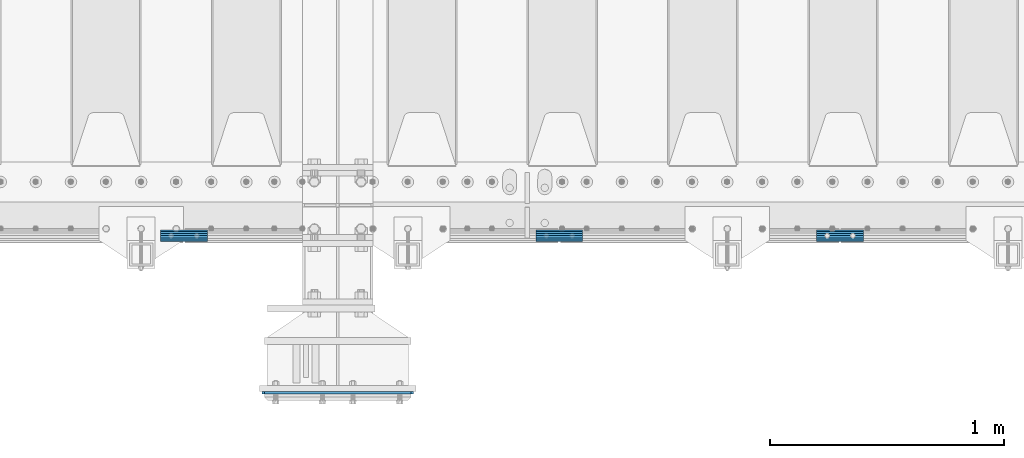
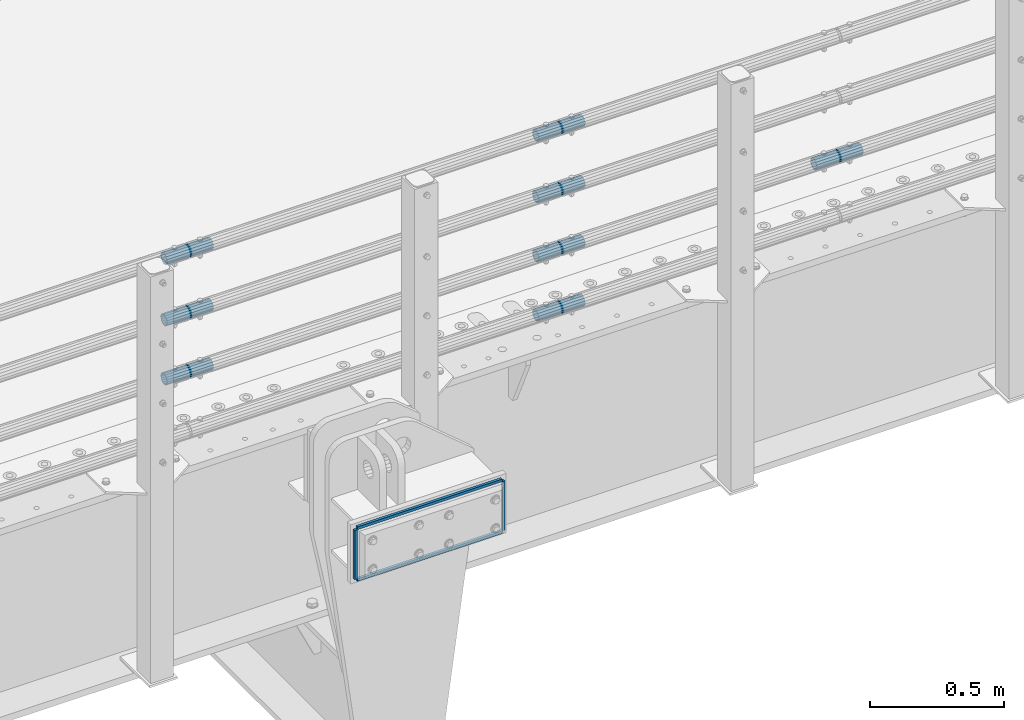
# One storey, part 116 of 193: 12 beams.
"""IFC2X3 building model written with IfcOpenShell, lengths in millimetres."""

from ifc_helpers import new_model, si_unit, frame, origin_with_axes, place, context, subcontext, project, spatial, faceted_brep, material, type_object, element, save


model = new_model("IFC2X3")

# Units and contexts
model_context = context("Model", 3, precision=1e-05, world=origin_with_axes())
body_context = subcontext(model_context, "Body", "Model", "MODEL_VIEW")
ifc_project = project(units=[si_unit("LENGTHUNIT", "METRE", prefix="MILLI"), si_unit("AREAUNIT", "SQUARE_METRE"), si_unit("VOLUMEUNIT", "CUBIC_METRE"), si_unit("MASSUNIT", "GRAM", prefix="KILO"), si_unit("TIMEUNIT", "SECOND"), si_unit("PLANEANGLEUNIT", "RADIAN"), si_unit("SOLIDANGLEUNIT", "STERADIAN"), si_unit("THERMODYNAMICTEMPERATUREUNIT", "DEGREE_CELSIUS"), si_unit("LUMINOUSINTENSITYUNIT", "LUMEN")], contexts=[model_context])

# Site, building, storey
site_placement = place(None, origin_with_axes())
site = spatial("IfcSite", under=ifc_project, at=site_placement, CompositionType="ELEMENT")
building_placement = place(site_placement, origin_with_axes())
building = spatial("IfcBuilding", under=site, at=building_placement, Name="Standard", CompositionType="ELEMENT")
storey_placement = place(building_placement, origin_with_axes())
storey = spatial("IfcBuildingStorey", under=building, at=storey_placement, Name="Undefined", CompositionType="ELEMENT", Elevation=0.0)

# Beams
ifc_material_1 = material(Name="STEEL/S355N")
beam_type_1 = type_object("IfcBeamType", PredefinedType="NOTDEFINED")
for number, where, z_axis, x_axis in (
    (1, (-32378.499999934, 23198.9999999954, -12.500018206186), (-1.0, 0.0, 0.0), (0.0, 0.0, -1.0)),
    (2, (-31741.4999999322, 23198.9999999952, -12.500018206186), (-1.0, 0.0, 0.0), (0.0, 0.0, -1.0)),
):
    element("IfcBeam", number, at=place(storey_placement, frame(where, z_axis=z_axis, x_axis=x_axis)), inside=storey, type_object=beam_type_1, material=ifc_material_1, context=body_context, shape_type="Brep", body=[
        faceted_brep([(0.0, 6.0, -6.0), (0.0, 6.0, 6.0), (225.0, 6.0, 6.0), (225.0, 6.0, -6.0), (0.0, -6.0, 6.0), (225.0, -6.0, 6.0), (0.0, -6.0, -6.0), (225.0, -6.0, -6.0)], [[[0, 1, 2, 3]], [[1, 4, 5, 2]], [[4, 6, 7, 5]], [[6, 0, 3, 7]], [[5, 7, 3, 2]], [[6, 4, 1, 0]]]),
    ])
for number, where, z_axis, x_axis in (
    (3, (-32372.4999999339, 23198.9999999954, -6.50001820618604), (0.0, 0.0, -1.0), (1.0, 0.0, 0.0)),
    (4, (-32372.4999999339, 23198.9999999954, -243.500018206186), (0.0, 0.0, -1.0), (1.0, 0.0, 0.0)),
):
    element("IfcBeam", number, at=place(storey_placement, frame(where, z_axis=z_axis, x_axis=x_axis)), inside=storey, type_object=beam_type_1, material=ifc_material_1, context=body_context, shape_type="Brep", body=[
        faceted_brep([(0.0, 6.0, -6.0), (0.0, 6.0, 6.0), (625.000000001688, 6.0, 6.0), (625.000000001688, 6.0, -6.0), (0.0, -6.0, 6.0), (625.000000001688, -6.0, 6.0), (0.0, -6.0, -6.0), (625.000000001688, -6.0, -6.0)], [[[0, 1, 2, 3]], [[1, 4, 5, 2]], [[4, 6, 7, 5]], [[6, 0, 3, 7]], [[5, 7, 3, 2]], [[6, 4, 1, 0]]]),
    ])
ifc_material_2 = material()
beam_type_2 = type_object("IfcBeamType", PredefinedType="NOTDEFINED")
beam_1_placement = place(storey_placement, frame((-31213.0024970001, 23870.1500000004, 149.849999999747), z_axis=(0.0, 0.0, 1.0), x_axis=(1.0, 0.0, 0.0)))
element("IfcBeam", 5, at=beam_1_placement, inside=storey, type_object=beam_type_2, material=ifc_material_2, context=body_context, shape_type="Brep", body=[
    faceted_brep([(0.0, -21.9000000000015, 0.0), (0.0, -20.232961761998, 8.38076716879547), (200.0, -20.232961761998, 8.38076716879547), (200.0, -21.9000000000015, 0.0), (0.0, -15.4856385079838, 15.4856385079854), (200.0, -15.4856385079838, 15.4856385079854), (0.0, -8.38076716879368, 20.2329617619972), (200.0, -8.38076716879368, 20.2329617619972), (0.0, 0.0, 21.9), (200.0, 0.0, 21.9), (0.0, 8.38076716879368, 20.2329617619972), (200.0, 8.38076716879368, 20.2329617619972), (0.0, 15.4856385079838, 15.4856385079854), (200.0, 15.4856385079838, 15.4856385079854), (0.0, 20.232961761998, 8.38076716879547), (200.0, 20.232961761998, 8.38076716879547), (0.0, 21.9000000000015, 0.0), (200.0, 21.9000000000015, 0.0), (0.0, 20.232961761998, -8.38076716879547), (200.0, 20.232961761998, -8.38076716879547), (0.0, 15.4856385079838, -15.4856385079854), (200.0, 15.4856385079838, -15.4856385079854), (0.0, 8.38076716879368, -20.2329617619972), (200.0, 8.38076716879368, -20.2329617619972), (0.0, 0.0, -21.9), (200.0, 0.0, -21.9), (0.0, -8.38076716879368, -20.2329617619972), (200.0, -8.38076716879368, -20.2329617619972), (0.0, -15.4856385079838, -15.4856385079854), (200.0, -15.4856385079838, -15.4856385079854), (0.0, -20.232961761998, -8.38076716879547), (200.0, -20.232961761998, -8.38076716879547), (0.0, -25.5, 0.0), (0.0, -23.5589280790373, -9.7584275253098), (200.0, -23.5589280790373, -9.7584275253098), (200.0, -25.5, 0.0), (0.0, -18.0312229202573, -18.031222920257), (200.0, -18.0312229202573, -18.031222920257), (0.0, -9.75842752531025, -23.5589280790378), (200.0, -9.75842752531025, -23.5589280790378), (0.0, 0.0, -25.5), (200.0, 0.0, -25.5), (0.0, 9.75842752531025, -23.5589280790378), (200.0, 9.75842752531025, -23.5589280790378), (0.0, 18.0312229202573, -18.031222920257), (200.0, 18.0312229202573, -18.031222920257), (0.0, 23.5589280790373, -9.7584275253098), (200.0, 23.5589280790373, -9.7584275253098), (0.0, 25.5, 0.0), (200.0, 25.5, 0.0), (0.0, 23.5589280790373, 9.7584275253098), (200.0, 23.5589280790373, 9.7584275253098), (0.0, 18.0312229202573, 18.031222920257), (200.0, 18.0312229202573, 18.031222920257), (0.0, 9.75842752531025, 23.5589280790378), (200.0, 9.75842752531025, 23.5589280790378), (0.0, 0.0, 25.5), (200.0, 0.0, 25.5), (0.0, -9.75842752531025, 23.5589280790378), (200.0, -9.75842752531025, 23.5589280790378), (0.0, -18.0312229202573, 18.031222920257), (200.0, -18.0312229202573, 18.031222920257), (0.0, -23.5589280790373, 9.7584275253098), (200.0, -23.5589280790373, 9.7584275253098)], [[[0, 1, 2, 3]], [[1, 4, 5, 2]], [[4, 6, 7, 5]], [[6, 8, 9, 7]], [[8, 10, 11, 9]], [[10, 12, 13, 11]], [[12, 14, 15, 13]], [[14, 16, 17, 15]], [[16, 18, 19, 17]], [[18, 20, 21, 19]], [[20, 22, 23, 21]], [[22, 24, 25, 23]], [[24, 26, 27, 25]], [[26, 28, 29, 27]], [[28, 30, 31, 29]], [[30, 0, 3, 31]], [[32, 33, 34, 35]], [[33, 36, 37, 34]], [[36, 38, 39, 37]], [[38, 40, 41, 39]], [[40, 42, 43, 41]], [[42, 44, 45, 43]], [[44, 46, 47, 45]], [[46, 48, 49, 47]], [[48, 50, 51, 49]], [[50, 52, 53, 51]], [[52, 54, 55, 53]], [[54, 56, 57, 55]], [[56, 58, 59, 57]], [[58, 60, 61, 59]], [[60, 62, 63, 61]], [[62, 32, 35, 63]], [[37, 39, 41, 43, 45, 47, 49, 51, 53, 55, 57, 59, 61, 63, 35, 34], [5, 7, 9, 11, 13, 15, 17, 19, 21, 23, 25, 27, 29, 31, 3, 2]], [[62, 60, 58, 56, 54, 52, 50, 48, 46, 44, 42, 40, 38, 36, 33, 32], [30, 28, 26, 24, 22, 20, 18, 16, 14, 12, 10, 8, 6, 4, 1, 0]]]),
])
beam_2_placement = place(storey_placement, frame((-32817.0024970001, 23870.1500000004, 420.149999999747), z_axis=(0.0, 0.0, 1.0), x_axis=(1.0, 0.0, 0.0)))
element("IfcBeam", 6, at=beam_2_placement, inside=storey, type_object=beam_type_2, material=ifc_material_2, context=body_context, shape_type="Brep", body=[
    faceted_brep([(0.0, -21.9000000000015, 0.0), (0.0, -20.232961761998, 8.38076716879547), (200.0, -20.232961761998, 8.38076716879547), (200.0, -21.9000000000015, 0.0), (0.0, -15.4856385079838, 15.4856385079854), (200.0, -15.4856385079838, 15.4856385079854), (0.0, -8.38076716879368, 20.2329617619972), (200.0, -8.38076716879368, 20.2329617619972), (0.0, 0.0, 21.9), (200.0, 0.0, 21.9), (0.0, 8.38076716879368, 20.2329617619972), (200.0, 8.38076716879368, 20.2329617619972), (0.0, 15.4856385079838, 15.4856385079854), (200.0, 15.4856385079838, 15.4856385079854), (0.0, 20.232961761998, 8.38076716879547), (200.0, 20.232961761998, 8.38076716879547), (0.0, 21.9000000000015, 0.0), (200.0, 21.9000000000015, 0.0), (0.0, 20.232961761998, -8.38076716879547), (200.0, 20.232961761998, -8.38076716879547), (0.0, 15.4856385079838, -15.4856385079854), (200.0, 15.4856385079838, -15.4856385079854), (0.0, 8.38076716879368, -20.2329617619972), (200.0, 8.38076716879368, -20.2329617619972), (0.0, 0.0, -21.9), (200.0, 0.0, -21.9), (0.0, -8.38076716879368, -20.2329617619972), (200.0, -8.38076716879368, -20.2329617619972), (0.0, -15.4856385079838, -15.4856385079854), (200.0, -15.4856385079838, -15.4856385079854), (0.0, -20.232961761998, -8.38076716879547), (200.0, -20.232961761998, -8.38076716879547), (0.0, -25.5, 0.0), (0.0, -23.5589280790373, -9.7584275253098), (200.0, -23.5589280790373, -9.7584275253098), (200.0, -25.5, 0.0), (0.0, -18.0312229202573, -18.031222920257), (200.0, -18.0312229202573, -18.031222920257), (0.0, -9.75842752531025, -23.5589280790378), (200.0, -9.75842752531025, -23.5589280790378), (0.0, 0.0, -25.5), (200.0, 0.0, -25.5), (0.0, 9.75842752531025, -23.5589280790378), (200.0, 9.75842752531025, -23.5589280790378), (0.0, 18.0312229202573, -18.031222920257), (200.0, 18.0312229202573, -18.031222920257), (0.0, 23.5589280790373, -9.7584275253098), (200.0, 23.5589280790373, -9.7584275253098), (0.0, 25.5, 0.0), (200.0, 25.5, 0.0), (0.0, 23.5589280790373, 9.7584275253098), (200.0, 23.5589280790373, 9.7584275253098), (0.0, 18.0312229202573, 18.031222920257), (200.0, 18.0312229202573, 18.031222920257), (0.0, 9.75842752531025, 23.5589280790378), (200.0, 9.75842752531025, 23.5589280790378), (0.0, 0.0, 25.5), (200.0, 0.0, 25.5), (0.0, -9.75842752531025, 23.5589280790378), (200.0, -9.75842752531025, 23.5589280790378), (0.0, -18.0312229202573, 18.031222920257), (200.0, -18.0312229202573, 18.031222920257), (0.0, -23.5589280790373, 9.7584275253098), (200.0, -23.5589280790373, 9.7584275253098)], [[[0, 1, 2, 3]], [[1, 4, 5, 2]], [[4, 6, 7, 5]], [[6, 8, 9, 7]], [[8, 10, 11, 9]], [[10, 12, 13, 11]], [[12, 14, 15, 13]], [[14, 16, 17, 15]], [[16, 18, 19, 17]], [[18, 20, 21, 19]], [[20, 22, 23, 21]], [[22, 24, 25, 23]], [[24, 26, 27, 25]], [[26, 28, 29, 27]], [[28, 30, 31, 29]], [[30, 0, 3, 31]], [[32, 33, 34, 35]], [[33, 36, 37, 34]], [[36, 38, 39, 37]], [[38, 40, 41, 39]], [[40, 42, 43, 41]], [[42, 44, 45, 43]], [[44, 46, 47, 45]], [[46, 48, 49, 47]], [[48, 50, 51, 49]], [[50, 52, 53, 51]], [[52, 54, 55, 53]], [[54, 56, 57, 55]], [[56, 58, 59, 57]], [[58, 60, 61, 59]], [[60, 62, 63, 61]], [[62, 32, 35, 63]], [[37, 39, 41, 43, 45, 47, 49, 51, 53, 55, 57, 59, 61, 63, 35, 34], [5, 7, 9, 11, 13, 15, 17, 19, 21, 23, 25, 27, 29, 31, 3, 2]], [[62, 60, 58, 56, 54, 52, 50, 48, 46, 44, 42, 40, 38, 36, 33, 32], [30, 28, 26, 24, 22, 20, 18, 16, 14, 12, 10, 8, 6, 4, 1, 0]]]),
])
beam_3_placement = place(storey_placement, frame((-31213.0024970001, 23870.1500000004, 420.149999999747), z_axis=(0.0, 0.0, 1.0), x_axis=(1.0, 0.0, 0.0)))
element("IfcBeam", 7, at=beam_3_placement, inside=storey, type_object=beam_type_2, material=ifc_material_2, context=body_context, shape_type="Brep", body=[
    faceted_brep([(0.0, -21.9000000000015, 0.0), (0.0, -20.232961761998, 8.38076716879547), (200.0, -20.232961761998, 8.38076716879547), (200.0, -21.9000000000015, 0.0), (0.0, -15.4856385079838, 15.4856385079854), (200.0, -15.4856385079838, 15.4856385079854), (0.0, -8.38076716879368, 20.2329617619972), (200.0, -8.38076716879368, 20.2329617619972), (0.0, 0.0, 21.9), (200.0, 0.0, 21.9), (0.0, 8.38076716879368, 20.2329617619972), (200.0, 8.38076716879368, 20.2329617619972), (0.0, 15.4856385079838, 15.4856385079854), (200.0, 15.4856385079838, 15.4856385079854), (0.0, 20.232961761998, 8.38076716879547), (200.0, 20.232961761998, 8.38076716879547), (0.0, 21.9000000000015, 0.0), (200.0, 21.9000000000015, 0.0), (0.0, 20.232961761998, -8.38076716879547), (200.0, 20.232961761998, -8.38076716879547), (0.0, 15.4856385079838, -15.4856385079854), (200.0, 15.4856385079838, -15.4856385079854), (0.0, 8.38076716879368, -20.2329617619972), (200.0, 8.38076716879368, -20.2329617619972), (0.0, 0.0, -21.9), (200.0, 0.0, -21.9), (0.0, -8.38076716879368, -20.2329617619972), (200.0, -8.38076716879368, -20.2329617619972), (0.0, -15.4856385079838, -15.4856385079854), (200.0, -15.4856385079838, -15.4856385079854), (0.0, -20.232961761998, -8.38076716879547), (200.0, -20.232961761998, -8.38076716879547), (0.0, -25.5, 0.0), (0.0, -23.5589280790373, -9.7584275253098), (200.0, -23.5589280790373, -9.7584275253098), (200.0, -25.5, 0.0), (0.0, -18.0312229202573, -18.031222920257), (200.0, -18.0312229202573, -18.031222920257), (0.0, -9.75842752531025, -23.5589280790378), (200.0, -9.75842752531025, -23.5589280790378), (0.0, 0.0, -25.5), (200.0, 0.0, -25.5), (0.0, 9.75842752531025, -23.5589280790378), (200.0, 9.75842752531025, -23.5589280790378), (0.0, 18.0312229202573, -18.031222920257), (200.0, 18.0312229202573, -18.031222920257), (0.0, 23.5589280790373, -9.7584275253098), (200.0, 23.5589280790373, -9.7584275253098), (0.0, 25.5, 0.0), (200.0, 25.5, 0.0), (0.0, 23.5589280790373, 9.7584275253098), (200.0, 23.5589280790373, 9.7584275253098), (0.0, 18.0312229202573, 18.031222920257), (200.0, 18.0312229202573, 18.031222920257), (0.0, 9.75842752531025, 23.5589280790378), (200.0, 9.75842752531025, 23.5589280790378), (0.0, 0.0, 25.5), (200.0, 0.0, 25.5), (0.0, -9.75842752531025, 23.5589280790378), (200.0, -9.75842752531025, 23.5589280790378), (0.0, -18.0312229202573, 18.031222920257), (200.0, -18.0312229202573, 18.031222920257), (0.0, -23.5589280790373, 9.7584275253098), (200.0, -23.5589280790373, 9.7584275253098)], [[[0, 1, 2, 3]], [[1, 4, 5, 2]], [[4, 6, 7, 5]], [[6, 8, 9, 7]], [[8, 10, 11, 9]], [[10, 12, 13, 11]], [[12, 14, 15, 13]], [[14, 16, 17, 15]], [[16, 18, 19, 17]], [[18, 20, 21, 19]], [[20, 22, 23, 21]], [[22, 24, 25, 23]], [[24, 26, 27, 25]], [[26, 28, 29, 27]], [[28, 30, 31, 29]], [[30, 0, 3, 31]], [[32, 33, 34, 35]], [[33, 36, 37, 34]], [[36, 38, 39, 37]], [[38, 40, 41, 39]], [[40, 42, 43, 41]], [[42, 44, 45, 43]], [[44, 46, 47, 45]], [[46, 48, 49, 47]], [[48, 50, 51, 49]], [[50, 52, 53, 51]], [[52, 54, 55, 53]], [[54, 56, 57, 55]], [[56, 58, 59, 57]], [[58, 60, 61, 59]], [[60, 62, 63, 61]], [[62, 32, 35, 63]], [[37, 39, 41, 43, 45, 47, 49, 51, 53, 55, 57, 59, 61, 63, 35, 34], [5, 7, 9, 11, 13, 15, 17, 19, 21, 23, 25, 27, 29, 31, 3, 2]], [[62, 60, 58, 56, 54, 52, 50, 48, 46, 44, 42, 40, 38, 36, 33, 32], [30, 28, 26, 24, 22, 20, 18, 16, 14, 12, 10, 8, 6, 4, 1, 0]]]),
])
beam_4_placement = place(storey_placement, frame((-32817.0024970001, 23870.1500000004, 969.849999999747), z_axis=(0.0, 0.0, 1.0), x_axis=(1.0, 0.0, 0.0)))
element("IfcBeam", 8, at=beam_4_placement, inside=storey, type_object=beam_type_2, material=ifc_material_2, context=body_context, shape_type="Brep", body=[
    faceted_brep([(0.0, -21.9000000000015, 0.0), (0.0, -20.232961761998, 8.38076716879547), (200.0, -20.232961761998, 8.38076716879547), (200.0, -21.9000000000015, 0.0), (0.0, -15.4856385079838, 15.4856385079854), (200.0, -15.4856385079838, 15.4856385079854), (0.0, -8.38076716879368, 20.2329617619972), (200.0, -8.38076716879368, 20.2329617619972), (0.0, 0.0, 21.9), (200.0, 0.0, 21.9), (0.0, 8.38076716879368, 20.2329617619972), (200.0, 8.38076716879368, 20.2329617619972), (0.0, 15.4856385079838, 15.4856385079854), (200.0, 15.4856385079838, 15.4856385079854), (0.0, 20.232961761998, 8.38076716879547), (200.0, 20.232961761998, 8.38076716879547), (0.0, 21.9000000000015, 0.0), (200.0, 21.9000000000015, 0.0), (0.0, 20.232961761998, -8.38076716879547), (200.0, 20.232961761998, -8.38076716879547), (0.0, 15.4856385079838, -15.4856385079854), (200.0, 15.4856385079838, -15.4856385079854), (0.0, 8.38076716879368, -20.2329617619972), (200.0, 8.38076716879368, -20.2329617619972), (0.0, 0.0, -21.9), (200.0, 0.0, -21.9), (0.0, -8.38076716879368, -20.2329617619972), (200.0, -8.38076716879368, -20.2329617619972), (0.0, -15.4856385079838, -15.4856385079854), (200.0, -15.4856385079838, -15.4856385079854), (0.0, -20.232961761998, -8.38076716879547), (200.0, -20.232961761998, -8.38076716879547), (0.0, -25.5, 0.0), (0.0, -23.5589280790373, -9.7584275253098), (200.0, -23.5589280790373, -9.7584275253098), (200.0, -25.5, 0.0), (0.0, -18.0312229202573, -18.031222920257), (200.0, -18.0312229202573, -18.031222920257), (0.0, -9.75842752531025, -23.5589280790378), (200.0, -9.75842752531025, -23.5589280790378), (0.0, 0.0, -25.5), (200.0, 0.0, -25.5), (0.0, 9.75842752531025, -23.5589280790378), (200.0, 9.75842752531025, -23.5589280790378), (0.0, 18.0312229202573, -18.031222920257), (200.0, 18.0312229202573, -18.031222920257), (0.0, 23.5589280790373, -9.7584275253098), (200.0, 23.5589280790373, -9.7584275253098), (0.0, 25.5, 0.0), (200.0, 25.5, 0.0), (0.0, 23.5589280790373, 9.7584275253098), (200.0, 23.5589280790373, 9.7584275253098), (0.0, 18.0312229202573, 18.031222920257), (200.0, 18.0312229202573, 18.031222920257), (0.0, 9.75842752531025, 23.5589280790378), (200.0, 9.75842752531025, 23.5589280790378), (0.0, 0.0, 25.5), (200.0, 0.0, 25.5), (0.0, -9.75842752531025, 23.5589280790378), (200.0, -9.75842752531025, 23.5589280790378), (0.0, -18.0312229202573, 18.031222920257), (200.0, -18.0312229202573, 18.031222920257), (0.0, -23.5589280790373, 9.7584275253098), (200.0, -23.5589280790373, 9.7584275253098)], [[[0, 1, 2, 3]], [[1, 4, 5, 2]], [[4, 6, 7, 5]], [[6, 8, 9, 7]], [[8, 10, 11, 9]], [[10, 12, 13, 11]], [[12, 14, 15, 13]], [[14, 16, 17, 15]], [[16, 18, 19, 17]], [[18, 20, 21, 19]], [[20, 22, 23, 21]], [[22, 24, 25, 23]], [[24, 26, 27, 25]], [[26, 28, 29, 27]], [[28, 30, 31, 29]], [[30, 0, 3, 31]], [[32, 33, 34, 35]], [[33, 36, 37, 34]], [[36, 38, 39, 37]], [[38, 40, 41, 39]], [[40, 42, 43, 41]], [[42, 44, 45, 43]], [[44, 46, 47, 45]], [[46, 48, 49, 47]], [[48, 50, 51, 49]], [[50, 52, 53, 51]], [[52, 54, 55, 53]], [[54, 56, 57, 55]], [[56, 58, 59, 57]], [[58, 60, 61, 59]], [[60, 62, 63, 61]], [[62, 32, 35, 63]], [[37, 39, 41, 43, 45, 47, 49, 51, 53, 55, 57, 59, 61, 63, 35, 34], [5, 7, 9, 11, 13, 15, 17, 19, 21, 23, 25, 27, 29, 31, 3, 2]], [[62, 60, 58, 56, 54, 52, 50, 48, 46, 44, 42, 40, 38, 36, 33, 32], [30, 28, 26, 24, 22, 20, 18, 16, 14, 12, 10, 8, 6, 4, 1, 0]]]),
])
beam_5_placement = place(storey_placement, frame((-31213.0024970001, 23870.1500000004, 969.849999999747), z_axis=(0.0, 0.0, 1.0), x_axis=(1.0, 0.0, 0.0)))
element("IfcBeam", 9, at=beam_5_placement, inside=storey, type_object=beam_type_2, material=ifc_material_2, context=body_context, shape_type="Brep", body=[
    faceted_brep([(0.0, -21.9000000000015, 0.0), (0.0, -20.232961761998, 8.38076716879547), (200.0, -20.232961761998, 8.38076716879547), (200.0, -21.9000000000015, 0.0), (0.0, -15.4856385079838, 15.4856385079854), (200.0, -15.4856385079838, 15.4856385079854), (0.0, -8.38076716879368, 20.2329617619972), (200.0, -8.38076716879368, 20.2329617619972), (0.0, 0.0, 21.9), (200.0, 0.0, 21.9), (0.0, 8.38076716879368, 20.2329617619972), (200.0, 8.38076716879368, 20.2329617619972), (0.0, 15.4856385079838, 15.4856385079854), (200.0, 15.4856385079838, 15.4856385079854), (0.0, 20.232961761998, 8.38076716879547), (200.0, 20.232961761998, 8.38076716879547), (0.0, 21.9000000000015, 0.0), (200.0, 21.9000000000015, 0.0), (0.0, 20.232961761998, -8.38076716879547), (200.0, 20.232961761998, -8.38076716879547), (0.0, 15.4856385079838, -15.4856385079854), (200.0, 15.4856385079838, -15.4856385079854), (0.0, 8.38076716879368, -20.2329617619972), (200.0, 8.38076716879368, -20.2329617619972), (0.0, 0.0, -21.9), (200.0, 0.0, -21.9), (0.0, -8.38076716879368, -20.2329617619972), (200.0, -8.38076716879368, -20.2329617619972), (0.0, -15.4856385079838, -15.4856385079854), (200.0, -15.4856385079838, -15.4856385079854), (0.0, -20.232961761998, -8.38076716879547), (200.0, -20.232961761998, -8.38076716879547), (0.0, -25.5, 0.0), (0.0, -23.5589280790373, -9.7584275253098), (200.0, -23.5589280790373, -9.7584275253098), (200.0, -25.5, 0.0), (0.0, -18.0312229202573, -18.031222920257), (200.0, -18.0312229202573, -18.031222920257), (0.0, -9.75842752531025, -23.5589280790378), (200.0, -9.75842752531025, -23.5589280790378), (0.0, 0.0, -25.5), (200.0, 0.0, -25.5), (0.0, 9.75842752531025, -23.5589280790378), (200.0, 9.75842752531025, -23.5589280790378), (0.0, 18.0312229202573, -18.031222920257), (200.0, 18.0312229202573, -18.031222920257), (0.0, 23.5589280790373, -9.7584275253098), (200.0, 23.5589280790373, -9.7584275253098), (0.0, 25.5, 0.0), (200.0, 25.5, 0.0), (0.0, 23.5589280790373, 9.7584275253098), (200.0, 23.5589280790373, 9.7584275253098), (0.0, 18.0312229202573, 18.031222920257), (200.0, 18.0312229202573, 18.031222920257), (0.0, 9.75842752531025, 23.5589280790378), (200.0, 9.75842752531025, 23.5589280790378), (0.0, 0.0, 25.5), (200.0, 0.0, 25.5), (0.0, -9.75842752531025, 23.5589280790378), (200.0, -9.75842752531025, 23.5589280790378), (0.0, -18.0312229202573, 18.031222920257), (200.0, -18.0312229202573, 18.031222920257), (0.0, -23.5589280790373, 9.7584275253098), (200.0, -23.5589280790373, 9.7584275253098)], [[[0, 1, 2, 3]], [[1, 4, 5, 2]], [[4, 6, 7, 5]], [[6, 8, 9, 7]], [[8, 10, 11, 9]], [[10, 12, 13, 11]], [[12, 14, 15, 13]], [[14, 16, 17, 15]], [[16, 18, 19, 17]], [[18, 20, 21, 19]], [[20, 22, 23, 21]], [[22, 24, 25, 23]], [[24, 26, 27, 25]], [[26, 28, 29, 27]], [[28, 30, 31, 29]], [[30, 0, 3, 31]], [[32, 33, 34, 35]], [[33, 36, 37, 34]], [[36, 38, 39, 37]], [[38, 40, 41, 39]], [[40, 42, 43, 41]], [[42, 44, 45, 43]], [[44, 46, 47, 45]], [[46, 48, 49, 47]], [[48, 50, 51, 49]], [[50, 52, 53, 51]], [[52, 54, 55, 53]], [[54, 56, 57, 55]], [[56, 58, 59, 57]], [[58, 60, 61, 59]], [[60, 62, 63, 61]], [[62, 32, 35, 63]], [[37, 39, 41, 43, 45, 47, 49, 51, 53, 55, 57, 59, 61, 63, 35, 34], [5, 7, 9, 11, 13, 15, 17, 19, 21, 23, 25, 27, 29, 31, 3, 2]], [[62, 60, 58, 56, 54, 52, 50, 48, 46, 44, 42, 40, 38, 36, 33, 32], [30, 28, 26, 24, 22, 20, 18, 16, 14, 12, 10, 8, 6, 4, 1, 0]]]),
])
beam_6_placement = place(storey_placement, frame((-30013.0024970001, 23870.1500000004, 419.849999999747), z_axis=(0.0, 0.0, 1.0), x_axis=(1.0, 0.0, 0.0)))
element("IfcBeam", 10, at=beam_6_placement, inside=storey, type_object=beam_type_2, material=ifc_material_2, context=body_context, shape_type="Brep", body=[
    faceted_brep([(0.0, -21.9000000000015, 0.0), (0.0, -20.232961761998, 8.38076716879547), (200.0, -20.232961761998, 8.38076716879547), (200.0, -21.9000000000015, 0.0), (0.0, -15.4856385079838, 15.4856385079854), (200.0, -15.4856385079838, 15.4856385079854), (0.0, -8.38076716879368, 20.2329617619972), (200.0, -8.38076716879368, 20.2329617619972), (0.0, 0.0, 21.9), (200.0, 0.0, 21.9), (0.0, 8.38076716879368, 20.2329617619972), (200.0, 8.38076716879368, 20.2329617619972), (0.0, 15.4856385079838, 15.4856385079854), (200.0, 15.4856385079838, 15.4856385079854), (0.0, 20.232961761998, 8.38076716879547), (200.0, 20.232961761998, 8.38076716879547), (0.0, 21.9000000000015, 0.0), (200.0, 21.9000000000015, 0.0), (0.0, 20.232961761998, -8.38076716879547), (200.0, 20.232961761998, -8.38076716879547), (0.0, 15.4856385079838, -15.4856385079854), (200.0, 15.4856385079838, -15.4856385079854), (0.0, 8.38076716879368, -20.2329617619972), (200.0, 8.38076716879368, -20.2329617619972), (0.0, 0.0, -21.9), (200.0, 0.0, -21.9), (0.0, -8.38076716879368, -20.2329617619972), (200.0, -8.38076716879368, -20.2329617619972), (0.0, -15.4856385079838, -15.4856385079854), (200.0, -15.4856385079838, -15.4856385079854), (0.0, -20.232961761998, -8.38076716879547), (200.0, -20.232961761998, -8.38076716879547), (0.0, -25.5, 0.0), (0.0, -23.5589280790373, -9.7584275253098), (200.0, -23.5589280790373, -9.7584275253098), (200.0, -25.5, 0.0), (0.0, -18.0312229202573, -18.031222920257), (200.0, -18.0312229202573, -18.031222920257), (0.0, -9.75842752531025, -23.5589280790378), (200.0, -9.75842752531025, -23.5589280790378), (0.0, 0.0, -25.5), (200.0, 0.0, -25.5), (0.0, 9.75842752531025, -23.5589280790378), (200.0, 9.75842752531025, -23.5589280790378), (0.0, 18.0312229202573, -18.031222920257), (200.0, 18.0312229202573, -18.031222920257), (0.0, 23.5589280790373, -9.7584275253098), (200.0, 23.5589280790373, -9.7584275253098), (0.0, 25.5, 0.0), (200.0, 25.5, 0.0), (0.0, 23.5589280790373, 9.7584275253098), (200.0, 23.5589280790373, 9.7584275253098), (0.0, 18.0312229202573, 18.031222920257), (200.0, 18.0312229202573, 18.031222920257), (0.0, 9.75842752531025, 23.5589280790378), (200.0, 9.75842752531025, 23.5589280790378), (0.0, 0.0, 25.5), (200.0, 0.0, 25.5), (0.0, -9.75842752531025, 23.5589280790378), (200.0, -9.75842752531025, 23.5589280790378), (0.0, -18.0312229202573, 18.031222920257), (200.0, -18.0312229202573, 18.031222920257), (0.0, -23.5589280790373, 9.7584275253098), (200.0, -23.5589280790373, 9.7584275253098)], [[[0, 1, 2, 3]], [[1, 4, 5, 2]], [[4, 6, 7, 5]], [[6, 8, 9, 7]], [[8, 10, 11, 9]], [[10, 12, 13, 11]], [[12, 14, 15, 13]], [[14, 16, 17, 15]], [[16, 18, 19, 17]], [[18, 20, 21, 19]], [[20, 22, 23, 21]], [[22, 24, 25, 23]], [[24, 26, 27, 25]], [[26, 28, 29, 27]], [[28, 30, 31, 29]], [[30, 0, 3, 31]], [[32, 33, 34, 35]], [[33, 36, 37, 34]], [[36, 38, 39, 37]], [[38, 40, 41, 39]], [[40, 42, 43, 41]], [[42, 44, 45, 43]], [[44, 46, 47, 45]], [[46, 48, 49, 47]], [[48, 50, 51, 49]], [[50, 52, 53, 51]], [[52, 54, 55, 53]], [[54, 56, 57, 55]], [[56, 58, 59, 57]], [[58, 60, 61, 59]], [[60, 62, 63, 61]], [[62, 32, 35, 63]], [[37, 39, 41, 43, 45, 47, 49, 51, 53, 55, 57, 59, 61, 63, 35, 34], [5, 7, 9, 11, 13, 15, 17, 19, 21, 23, 25, 27, 29, 31, 3, 2]], [[62, 60, 58, 56, 54, 52, 50, 48, 46, 44, 42, 40, 38, 36, 33, 32], [30, 28, 26, 24, 22, 20, 18, 16, 14, 12, 10, 8, 6, 4, 1, 0]]]),
])
beam_7_placement = place(storey_placement, frame((-32817.0024970001, 23870.1500000004, 689.849999999747), z_axis=(0.0, 0.0, 1.0), x_axis=(1.0, 0.0, 0.0)))
element("IfcBeam", 11, at=beam_7_placement, inside=storey, type_object=beam_type_2, material=ifc_material_2, context=body_context, shape_type="Brep", body=[
    faceted_brep([(0.0, -21.9000000000015, 0.0), (0.0, -20.232961761998, 8.38076716879547), (200.0, -20.232961761998, 8.38076716879547), (200.0, -21.9000000000015, 0.0), (0.0, -15.4856385079838, 15.4856385079854), (200.0, -15.4856385079838, 15.4856385079854), (0.0, -8.38076716879368, 20.2329617619972), (200.0, -8.38076716879368, 20.2329617619972), (0.0, 0.0, 21.9), (200.0, 0.0, 21.9), (0.0, 8.38076716879368, 20.2329617619972), (200.0, 8.38076716879368, 20.2329617619972), (0.0, 15.4856385079838, 15.4856385079854), (200.0, 15.4856385079838, 15.4856385079854), (0.0, 20.232961761998, 8.38076716879547), (200.0, 20.232961761998, 8.38076716879547), (0.0, 21.9000000000015, 0.0), (200.0, 21.9000000000015, 0.0), (0.0, 20.232961761998, -8.38076716879547), (200.0, 20.232961761998, -8.38076716879547), (0.0, 15.4856385079838, -15.4856385079854), (200.0, 15.4856385079838, -15.4856385079854), (0.0, 8.38076716879368, -20.2329617619972), (200.0, 8.38076716879368, -20.2329617619972), (0.0, 0.0, -21.9), (200.0, 0.0, -21.9), (0.0, -8.38076716879368, -20.2329617619972), (200.0, -8.38076716879368, -20.2329617619972), (0.0, -15.4856385079838, -15.4856385079854), (200.0, -15.4856385079838, -15.4856385079854), (0.0, -20.232961761998, -8.38076716879547), (200.0, -20.232961761998, -8.38076716879547), (0.0, -25.5, 0.0), (0.0, -23.5589280790373, -9.7584275253098), (200.0, -23.5589280790373, -9.7584275253098), (200.0, -25.5, 0.0), (0.0, -18.0312229202573, -18.031222920257), (200.0, -18.0312229202573, -18.031222920257), (0.0, -9.75842752531025, -23.5589280790378), (200.0, -9.75842752531025, -23.5589280790378), (0.0, 0.0, -25.5), (200.0, 0.0, -25.5), (0.0, 9.75842752531025, -23.5589280790378), (200.0, 9.75842752531025, -23.5589280790378), (0.0, 18.0312229202573, -18.031222920257), (200.0, 18.0312229202573, -18.031222920257), (0.0, 23.5589280790373, -9.7584275253098), (200.0, 23.5589280790373, -9.7584275253098), (0.0, 25.5, 0.0), (200.0, 25.5, 0.0), (0.0, 23.5589280790373, 9.7584275253098), (200.0, 23.5589280790373, 9.7584275253098), (0.0, 18.0312229202573, 18.031222920257), (200.0, 18.0312229202573, 18.031222920257), (0.0, 9.75842752531025, 23.5589280790378), (200.0, 9.75842752531025, 23.5589280790378), (0.0, 0.0, 25.5), (200.0, 0.0, 25.5), (0.0, -9.75842752531025, 23.5589280790378), (200.0, -9.75842752531025, 23.5589280790378), (0.0, -18.0312229202573, 18.031222920257), (200.0, -18.0312229202573, 18.031222920257), (0.0, -23.5589280790373, 9.7584275253098), (200.0, -23.5589280790373, 9.7584275253098)], [[[0, 1, 2, 3]], [[1, 4, 5, 2]], [[4, 6, 7, 5]], [[6, 8, 9, 7]], [[8, 10, 11, 9]], [[10, 12, 13, 11]], [[12, 14, 15, 13]], [[14, 16, 17, 15]], [[16, 18, 19, 17]], [[18, 20, 21, 19]], [[20, 22, 23, 21]], [[22, 24, 25, 23]], [[24, 26, 27, 25]], [[26, 28, 29, 27]], [[28, 30, 31, 29]], [[30, 0, 3, 31]], [[32, 33, 34, 35]], [[33, 36, 37, 34]], [[36, 38, 39, 37]], [[38, 40, 41, 39]], [[40, 42, 43, 41]], [[42, 44, 45, 43]], [[44, 46, 47, 45]], [[46, 48, 49, 47]], [[48, 50, 51, 49]], [[50, 52, 53, 51]], [[52, 54, 55, 53]], [[54, 56, 57, 55]], [[56, 58, 59, 57]], [[58, 60, 61, 59]], [[60, 62, 63, 61]], [[62, 32, 35, 63]], [[37, 39, 41, 43, 45, 47, 49, 51, 53, 55, 57, 59, 61, 63, 35, 34], [5, 7, 9, 11, 13, 15, 17, 19, 21, 23, 25, 27, 29, 31, 3, 2]], [[62, 60, 58, 56, 54, 52, 50, 48, 46, 44, 42, 40, 38, 36, 33, 32], [30, 28, 26, 24, 22, 20, 18, 16, 14, 12, 10, 8, 6, 4, 1, 0]]]),
])
beam_8_placement = place(storey_placement, frame((-31213.0024970001, 23870.1500000004, 689.849999999747), z_axis=(0.0, 0.0, 1.0), x_axis=(1.0, 0.0, 0.0)))
element("IfcBeam", 12, at=beam_8_placement, inside=storey, type_object=beam_type_2, material=ifc_material_2, context=body_context, shape_type="Brep", body=[
    faceted_brep([(0.0, -21.9000000000015, 0.0), (0.0, -20.232961761998, 8.38076716879547), (200.0, -20.232961761998, 8.38076716879547), (200.0, -21.9000000000015, 0.0), (0.0, -15.4856385079838, 15.4856385079854), (200.0, -15.4856385079838, 15.4856385079854), (0.0, -8.38076716879368, 20.2329617619972), (200.0, -8.38076716879368, 20.2329617619972), (0.0, 0.0, 21.9), (200.0, 0.0, 21.9), (0.0, 8.38076716879368, 20.2329617619972), (200.0, 8.38076716879368, 20.2329617619972), (0.0, 15.4856385079838, 15.4856385079854), (200.0, 15.4856385079838, 15.4856385079854), (0.0, 20.232961761998, 8.38076716879547), (200.0, 20.232961761998, 8.38076716879547), (0.0, 21.9000000000015, 0.0), (200.0, 21.9000000000015, 0.0), (0.0, 20.232961761998, -8.38076716879547), (200.0, 20.232961761998, -8.38076716879547), (0.0, 15.4856385079838, -15.4856385079854), (200.0, 15.4856385079838, -15.4856385079854), (0.0, 8.38076716879368, -20.2329617619972), (200.0, 8.38076716879368, -20.2329617619972), (0.0, 0.0, -21.9), (200.0, 0.0, -21.9), (0.0, -8.38076716879368, -20.2329617619972), (200.0, -8.38076716879368, -20.2329617619972), (0.0, -15.4856385079838, -15.4856385079854), (200.0, -15.4856385079838, -15.4856385079854), (0.0, -20.232961761998, -8.38076716879547), (200.0, -20.232961761998, -8.38076716879547), (0.0, -25.5, 0.0), (0.0, -23.5589280790373, -9.7584275253098), (200.0, -23.5589280790373, -9.7584275253098), (200.0, -25.5, 0.0), (0.0, -18.0312229202573, -18.031222920257), (200.0, -18.0312229202573, -18.031222920257), (0.0, -9.75842752531025, -23.5589280790378), (200.0, -9.75842752531025, -23.5589280790378), (0.0, 0.0, -25.5), (200.0, 0.0, -25.5), (0.0, 9.75842752531025, -23.5589280790378), (200.0, 9.75842752531025, -23.5589280790378), (0.0, 18.0312229202573, -18.031222920257), (200.0, 18.0312229202573, -18.031222920257), (0.0, 23.5589280790373, -9.7584275253098), (200.0, 23.5589280790373, -9.7584275253098), (0.0, 25.5, 0.0), (200.0, 25.5, 0.0), (0.0, 23.5589280790373, 9.7584275253098), (200.0, 23.5589280790373, 9.7584275253098), (0.0, 18.0312229202573, 18.031222920257), (200.0, 18.0312229202573, 18.031222920257), (0.0, 9.75842752531025, 23.5589280790378), (200.0, 9.75842752531025, 23.5589280790378), (0.0, 0.0, 25.5), (200.0, 0.0, 25.5), (0.0, -9.75842752531025, 23.5589280790378), (200.0, -9.75842752531025, 23.5589280790378), (0.0, -18.0312229202573, 18.031222920257), (200.0, -18.0312229202573, 18.031222920257), (0.0, -23.5589280790373, 9.7584275253098), (200.0, -23.5589280790373, 9.7584275253098)], [[[0, 1, 2, 3]], [[1, 4, 5, 2]], [[4, 6, 7, 5]], [[6, 8, 9, 7]], [[8, 10, 11, 9]], [[10, 12, 13, 11]], [[12, 14, 15, 13]], [[14, 16, 17, 15]], [[16, 18, 19, 17]], [[18, 20, 21, 19]], [[20, 22, 23, 21]], [[22, 24, 25, 23]], [[24, 26, 27, 25]], [[26, 28, 29, 27]], [[28, 30, 31, 29]], [[30, 0, 3, 31]], [[32, 33, 34, 35]], [[33, 36, 37, 34]], [[36, 38, 39, 37]], [[38, 40, 41, 39]], [[40, 42, 43, 41]], [[42, 44, 45, 43]], [[44, 46, 47, 45]], [[46, 48, 49, 47]], [[48, 50, 51, 49]], [[50, 52, 53, 51]], [[52, 54, 55, 53]], [[54, 56, 57, 55]], [[56, 58, 59, 57]], [[58, 60, 61, 59]], [[60, 62, 63, 61]], [[62, 32, 35, 63]], [[37, 39, 41, 43, 45, 47, 49, 51, 53, 55, 57, 59, 61, 63, 35, 34], [5, 7, 9, 11, 13, 15, 17, 19, 21, 23, 25, 27, 29, 31, 3, 2]], [[62, 60, 58, 56, 54, 52, 50, 48, 46, 44, 42, 40, 38, 36, 33, 32], [30, 28, 26, 24, 22, 20, 18, 16, 14, 12, 10, 8, 6, 4, 1, 0]]]),
])

save(model, "model.ifc")
